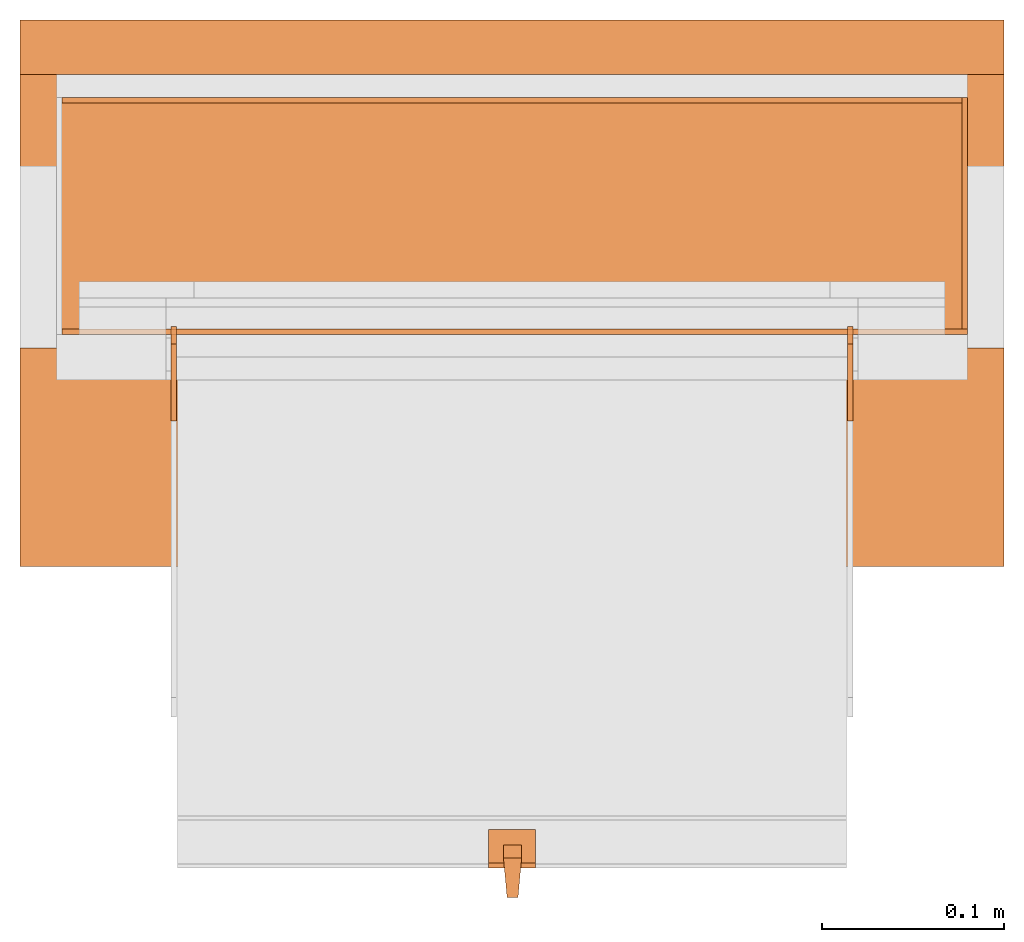
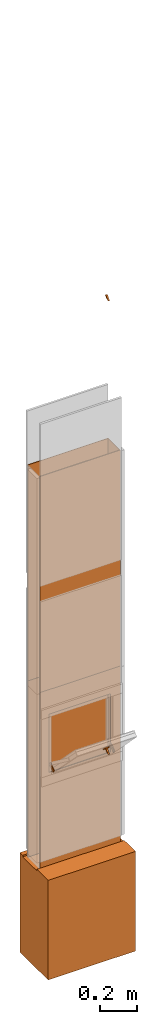
# One storey, part 4 of 4: 12 proxies, 1 opening.
"""IFC2X3 building model written with IfcOpenShell, lengths in metres."""

from ifc_helpers import new_model, entity, si_unit, converted_unit, derived_unit, money_unit, direction, frame, origin_with_axes, origin_2d_with_axis, place, context, subcontext, project, spatial, polyline, rectangle, outline, extrude, boolean, faceted_brep, source, transform, mapped, material, type_object, element, save


model = new_model("IFC2X3")

# Units and contexts
model_context = context("Model", 3, precision=1e-05, world=origin_with_axes(), true_north=direction((0.0, 1.0)))
plan_context = context("Plan", 3, precision=1e-05, world=origin_with_axes(), true_north=direction((0.0, 1.0)))
body_context = subcontext(model_context, "Body", "Model", "MODEL_VIEW")
ifc_project = project(units=[si_unit("LENGTHUNIT", "METRE"), si_unit("AREAUNIT", "SQUARE_METRE"), si_unit("VOLUMEUNIT", "CUBIC_METRE"), converted_unit("PLANEANGLEUNIT", "DEGREE", entity("IfcPlaneAngleMeasure", 0.0174532925199), si_unit("PLANEANGLEUNIT", "RADIAN"), dimensions=[0, 0, 0, 0, 0, 0, 0]), si_unit("SOLIDANGLEUNIT", "STERADIAN"), money_unit("CHF"), converted_unit("TIMEUNIT", "Year", entity("IfcTimeMeasure", 31556926.0), si_unit("TIMEUNIT", "SECOND"), dimensions=[0, 0, 1, 0, 0, 0, 0]), si_unit("MASSUNIT", "GRAM", prefix="KILO"), si_unit("THERMODYNAMICTEMPERATUREUNIT", "DEGREE_CELSIUS"), si_unit("LUMINOUSINTENSITYUNIT", "LUMEN"), si_unit("ENERGYUNIT", "JOULE", prefix="MEGA"), derived_unit("THERMALCONDUCTANCEUNIT", [(si_unit("POWERUNIT", "WATT"), 1), (si_unit("LENGTHUNIT", "METRE"), -1), (si_unit("THERMODYNAMICTEMPERATUREUNIT", "KELVIN"), -1)]), derived_unit("SPECIFICHEATCAPACITYUNIT", [(si_unit("ENERGYUNIT", "JOULE"), 1), (si_unit("MASSUNIT", "GRAM", prefix="KILO"), -1), (si_unit("THERMODYNAMICTEMPERATUREUNIT", "KELVIN"), -1)]), derived_unit("MASSDENSITYUNIT", [(si_unit("MASSUNIT", "GRAM", prefix="KILO"), 1), (si_unit("VOLUMEUNIT", "CUBIC_METRE"), -1)])], contexts=[model_context, plan_context])

# Site, building, storey
site_placement = place(None, origin_with_axes())
site = spatial("IfcSite", under=ifc_project, at=site_placement, CompositionType="ELEMENT")
building_placement = place(site_placement, origin_with_axes())
building = spatial("IfcBuilding", under=site, at=building_placement, CompositionType="ELEMENT")
storey_placement = place(building_placement, origin_with_axes())
storey = spatial("IfcBuildingStorey", under=building, at=storey_placement, Name="EG00", CompositionType="ELEMENT", Elevation=0.0)

# Proxies
ifc_material_1 = material(Name="Metall, Stahl")
building_element_proxy_type_1 = type_object("IfcBuildingElementProxyType", Name="Metall, Stahl 3", PredefinedType="NOTDEFINED")
proxy_1_placement = place(storey_placement, frame((9.61522436818, -8.09743070606, 0.0), z_axis=(0.0, 0.0, 1.0), x_axis=(-1.0, 0.0, 0.0)))
element("IfcBuildingElementProxy", 1, at=proxy_1_placement, inside=storey, type_object=building_element_proxy_type_1, material=ifc_material_1, Name="Wand-008", context=body_context, shape_type="CSG", body=[
    boolean("DIFFERENCE", boolean("DIFFERENCE", extrude(outline(polyline([(0.0, 0.0), (0.5, 0.0), (0.5, 0.003), (0.0, 0.003), (0.0, 0.0)])), origin_with_axes(), (0.0, 0.0, 1.0), 1.15), faceted_brep([(0.497, 0.003, 1.15), (0.497, 0.0, 1.15), (0.5, 0.0, 1.15), (0.5, 0.003, 1.15), (0.497, 0.0, 0.0), (0.497, 0.003, 0.0), (0.5, 0.0, 0.0), (0.5, 0.003, 0.0)], [[[0, 1, 2, 3]], [[4, 1, 0, 5]], [[1, 4, 6, 2]], [[2, 6, 7, 3]], [[5, 0, 3, 7]], [[4, 5, 7, 6]]])), faceted_brep([(0.003, 0.0, 0.0), (0.003, 0.0, 1.15), (0.0, 0.0, 1.15), (0.0, 0.0, 0.0), (0.003, 0.003, 1.15), (0.003, 0.003, 0.0), (0.0, 0.003, 1.15), (0.0, 0.003, 0.0)], [[[0, 1, 2, 3]], [[4, 1, 0, 5]], [[1, 4, 6, 2]], [[6, 7, 3, 2]], [[5, 0, 3, 7]], [[4, 5, 7, 6]]])),
])
proxy_2_placement = place(storey_placement, frame((9.61522436818, -8.22743070606, 0.0), z_axis=(0.0, 0.0, 1.0), x_axis=(0.0, 1.0, 0.0)))
element("IfcBuildingElementProxy", 2, at=proxy_2_placement, inside=storey, type_object=building_element_proxy_type_1, material=ifc_material_1, Name="Wand-007", context=body_context, shape_type="CSG", body=[
    boolean("DIFFERENCE", extrude(outline(polyline([(0.0, 0.0), (0.13, 0.0), (0.13, 0.003), (0.0, 0.003), (0.0, 0.0)])), origin_with_axes(), (0.0, 0.0, 1.0), 1.15), faceted_brep([(0.003, 0.0, 0.0), (0.003, 0.0, 1.15), (0.0, 0.0, 1.15), (0.0, 0.0, 0.0), (0.003, 0.003, 1.15), (0.003, 0.003, 0.0), (0.0, 0.003, 1.15), (0.0, 0.003, 0.0)], [[[0, 1, 2, 3]], [[4, 1, 0, 5]], [[1, 4, 6, 2]], [[6, 7, 3, 2]], [[5, 0, 3, 7]], [[4, 5, 7, 6]]])),
])

# Proxy, opening
proxy_3_placement = place(storey_placement, frame((9.11522436818, -8.22743070606, 0.0), z_axis=(0.0, 0.0, 1.0), x_axis=(1.0, 0.0, 0.0)))
proxy_3 = element("IfcBuildingElementProxy", 3, at=proxy_3_placement, inside=storey, type_object=building_element_proxy_type_1, material=ifc_material_1, Name="Wand-006", context=body_context, shape_type="CSG", body=[
    boolean("DIFFERENCE", extrude(outline(polyline([(0.0, 0.0), (0.5, 0.0), (0.5, 0.003), (0.0, 0.003), (0.0, 0.0)])), origin_with_axes(), (0.0, 0.0, 1.0), 1.15), faceted_brep([(0.003, 0.0, 1.15), (0.003, 0.003, 1.15), (0.0, 0.003, 1.15), (0.0, 0.0, 1.15), (0.003, 0.003, 0.0), (0.003, 0.0, 0.0), (0.0, 0.003, 0.0), (0.0, 0.0, 0.0)], [[[0, 1, 2, 3]], [[4, 1, 0, 5]], [[1, 4, 6, 2]], [[2, 6, 7, 3]], [[5, 0, 3, 7]], [[4, 5, 7, 6]]])),
])
opening_placement = place(proxy_3_placement, frame((-9.11522436818, 8.22743070606, 0.0), z_axis=(0.0, 0.0, 1.0), x_axis=(1.0, 0.0, 0.0)))
element("IfcOpeningElement", 4, at=opening_placement, cuts=proxy_3, Name="031", context=body_context, shape_type="SweptSolid", body=[
    extrude(rectangle(XDim=0.38, YDim=0.38, at=origin_2d_with_axis()), frame((9.36522436818, -8.25243070606, 0.8), z_axis=(0.0, -1.0, 0.0), x_axis=(1.0, 0.0, 0.0)), (0.0, 0.0, -1.0), 0.031),
])

# Proxies
proxy_4_placement = place(storey_placement, frame((9.61522436818, -8.09743070606, 1.15), z_axis=(0.0, 0.0, 1.0), x_axis=(-1.0, 0.0, 0.0)))
element("IfcBuildingElementProxy", 5, at=proxy_4_placement, inside=storey, type_object=building_element_proxy_type_1, material=ifc_material_1, Name="Wand-008", context=body_context, shape_type="CSG", body=[
    boolean("DIFFERENCE", boolean("DIFFERENCE", extrude(outline(polyline([(0.0, 0.0), (0.5, 0.0), (0.5, 0.003), (0.0, 0.003), (0.0, 0.0)])), origin_with_axes(), (0.0, 0.0, 1.0), 1.41), faceted_brep([(0.497, 0.003, 1.41), (0.497, 0.0, 1.41), (0.5, 0.0, 1.41), (0.5, 0.003, 1.41), (0.497, 0.0, 0.0), (0.497, 0.003, 0.0), (0.5, 0.0, 0.0), (0.5, 0.003, 0.0)], [[[0, 1, 2, 3]], [[4, 1, 0, 5]], [[1, 4, 6, 2]], [[2, 6, 7, 3]], [[5, 0, 3, 7]], [[4, 5, 7, 6]]])), faceted_brep([(0.003, 0.0, 0.0), (0.003, 0.0, 1.41), (0.0, 0.0, 1.41), (0.0, 0.0, 0.0), (0.003, 0.003, 1.41), (0.003, 0.003, 0.0), (0.0, 0.003, 1.41), (0.0, 0.003, 0.0)], [[[0, 1, 2, 3]], [[4, 1, 0, 5]], [[1, 4, 6, 2]], [[6, 7, 3, 2]], [[5, 0, 3, 7]], [[4, 5, 7, 6]]])),
])
proxy_5_placement = place(storey_placement, frame((9.61522436818, -8.22743070606, 1.15), z_axis=(0.0, 0.0, 1.0), x_axis=(0.0, 1.0, 0.0)))
element("IfcBuildingElementProxy", 6, at=proxy_5_placement, inside=storey, type_object=building_element_proxy_type_1, material=ifc_material_1, Name="Wand-007", context=body_context, shape_type="CSG", body=[
    boolean("DIFFERENCE", extrude(outline(polyline([(0.0, 0.0), (0.13, 0.0), (0.13, 0.003), (0.0, 0.003), (0.0, 0.0)])), origin_with_axes(), (0.0, 0.0, 1.0), 1.41), faceted_brep([(0.003, 0.0, 0.0), (0.003, 0.0, 1.41), (0.0, 0.0, 1.41), (0.0, 0.0, 0.0), (0.003, 0.003, 1.41), (0.003, 0.003, 0.0), (0.0, 0.003, 1.41), (0.0, 0.003, 0.0)], [[[0, 1, 2, 3]], [[4, 1, 0, 5]], [[1, 4, 6, 2]], [[6, 7, 3, 2]], [[5, 0, 3, 7]], [[4, 5, 7, 6]]])),
])
proxy_6_placement = place(storey_placement, frame((9.11522436818, -8.22743070606, 1.15), z_axis=(0.0, 0.0, 1.0), x_axis=(1.0, 0.0, 0.0)))
element("IfcBuildingElementProxy", 7, at=proxy_6_placement, inside=storey, type_object=building_element_proxy_type_1, material=ifc_material_1, Name="Wand-006", context=body_context, shape_type="CSG", body=[
    boolean("DIFFERENCE", extrude(outline(polyline([(0.0, 0.0), (0.5, 0.0), (0.5, 0.003), (0.0, 0.003), (0.0, 0.0)])), origin_with_axes(), (0.0, 0.0, 1.0), 1.41), faceted_brep([(0.003, 0.0, 1.41), (0.003, 0.003, 1.41), (0.0, 0.003, 1.41), (0.0, 0.0, 1.41), (0.003, 0.003, 0.0), (0.003, 0.0, 0.0), (0.0, 0.003, 0.0), (0.0, 0.0, 0.0)], [[[0, 1, 2, 3]], [[4, 1, 0, 5]], [[1, 4, 6, 2]], [[2, 6, 7, 3]], [[5, 0, 3, 7]], [[4, 5, 7, 6]]])),
])
ifc_material_2 = material(Name="Metall, Aluminium")
building_element_proxy_type_2 = type_object("IfcBuildingElementProxyType", Name="Metall, Aluminium", PredefinedType="NOTDEFINED")
shared_shape_1 = source(origin_with_axes(), body_context, "Body", "Brep", [
    faceted_brep([(16.3891379247, -3.43334637562, 1.097), (16.3891379247, -3.44334637562, 1.097), (16.3921379247, -3.43534637562, 1.13058255688), (16.3991379247, -3.43334637562, 1.097), (16.3991379247, -3.44334637562, 1.097), (16.3921379247, -3.44134637562, 1.13058255688), (16.3961379247, -3.43523159518, 1.13058255688), (16.3961379247, -3.4414517679, 1.13058255688)], [[[0, 1, 2]], [[1, 0, 3, 4]], [[1, 5, 2]], [[0, 2, 3]], [[4, 3, 6]], [[5, 1, 4]], [[2, 5, 7]], [[3, 2, 6]], [[6, 7, 4]], [[7, 5, 4]], [[2, 7, 6]]]),
])
for number, where, z_axis, x_axis, name in (
    (8, (12.8038684551, -19.2080620883, 13.3444423362), (0.0, -0.713898265506, -0.700249431636), (0.0, 0.700249431636, -0.713898265506), "Wand-008"),
    (9, (12.8038684551, -19.2080620883, 16.3044423362), (0.0, -0.713898265506, -0.700249431636), (0.0, 0.700249431636, -0.713898265506), "Wand-008"),
):
    element("IfcBuildingElementProxy", number, at=place(storey_placement, frame(where, z_axis=z_axis, x_axis=x_axis)), inside=storey, type_object=building_element_proxy_type_2, material=ifc_material_2, Name=name, context=body_context, shape_type="MappedRepresentation", body=[
        mapped(shared_shape_1, transform((0.0, 0.0, 0.0))),
    ])
shared_shape_2 = source(origin_with_axes(), body_context, "Body", "Brep", [
    faceted_brep([(16.1345115895, -3.59726483298, 0.726478855326), (16.1345115895, -3.60026483298, 0.726478855326), (16.1345115895, -3.60026483298, 0.776478855326), (16.1345115895, -3.59726483298, 0.776478855326), (16.1525115895, -3.60026483298, 0.726478855326), (16.1525115895, -3.59726483298, 0.726478855326), (16.1525115895, -3.60026483298, 0.776478855326), (16.1525115895, -3.59726483298, 0.776478855326)], [[[0, 1, 2, 3]], [[4, 1, 0, 5]], [[1, 4, 6, 2]], [[2, 6, 7, 3]], [[0, 3, 7, 5]], [[4, 5, 7, 6]]]),
])
for number, where, z_axis, x_axis, name in (
    (10, (13.1494892012, -16.2173099117, 14.7145311427), (0.0, -0.846133712697, -0.532970674838), (0.0, 0.532970674838, -0.846133712697), "Wand-005"),
    (11, (12.7784892012, -16.2173099117, 14.7145311427), (0.0, -0.846133712697, -0.532970674838), (0.0, 0.532970674838, -0.846133712697), "Wand-005"),
):
    element("IfcBuildingElementProxy", number, at=place(storey_placement, frame(where, z_axis=z_axis, x_axis=x_axis)), inside=storey, type_object=building_element_proxy_type_2, material=ifc_material_2, Name=name, context=body_context, shape_type="MappedRepresentation", body=[
        mapped(shared_shape_2, transform((0.0, 0.0, 0.0))),
    ])
shared_shape_3 = source(origin_with_axes(), body_context, "Body", "Brep", [
    faceted_brep([(16.3888858635, -3.43025891523, 1.114), (16.3888858635, -3.43025891523, 1.14), (16.3888858635, -3.40425891523, 1.14), (16.3888858635, -3.40425891523, 1.114), (16.3928858635, -3.43025891523, 1.114), (16.3928858635, -3.43025891523, 1.14), (16.3928858635, -3.40825891523, 1.14), (16.3928858635, -3.40425891523, 1.14), (16.3928858635, -3.40425891523, 1.114), (16.3928858635, -3.40825891523, 1.114)], [[[0, 1, 2, 3]], [[1, 0, 4]], [[2, 1, 5, 6, 7]], [[3, 2, 7, 8]], [[0, 3, 8, 9, 4]], [[1, 4, 5]], [[6, 5, 4]], [[6, 9, 8, 7]], [[9, 6, 4]]]),
])
proxy_7_placement = place(storey_placement, frame((12.7824832834, 3.98081117247, 11.5470677443), z_axis=(0.0, -0.700249431637, 0.713898265506), x_axis=(0.0, -0.713898265506, -0.700249431637)))
element("IfcBuildingElementProxy", 12, at=proxy_7_placement, inside=storey, type_object=building_element_proxy_type_2, material=ifc_material_2, Name="Wand-007", context=body_context, shape_type="MappedRepresentation", body=[
    mapped(shared_shape_3, transform((0.0, 0.0, 0.0))),
])
ifc_material_3 = material(Name="Luft, horizontal")
building_element_proxy_type_3 = type_object("IfcBuildingElementProxyType", Name="Luft, horizontal 650", PredefinedType="NOTDEFINED")
proxy_8_placement = place(storey_placement, frame((9.09522436818, -8.35493070606, 0.01), z_axis=(0.0, 0.0, 1.0), x_axis=(1.0, 0.0, 0.0)))
element("IfcBuildingElementProxy", 13, at=proxy_8_placement, inside=storey, type_object=building_element_proxy_type_3, material=ifc_material_3, Name="Decke-007", context=body_context, shape_type="CSG", body=[
    boolean("DIFFERENCE", extrude(outline(polyline([(0.0, 0.0), (0.54, 0.0), (0.54, 0.3), (0.0, 0.3), (0.0, 0.0)])), frame((0.0, 0.0, -0.649830794263), z_axis=(0.0, 0.0, 1.0), x_axis=(1.0, 0.0, 0.0)), (0.0, 0.0, 1.0), 0.649830794263), faceted_brep([(0.54, 0.12, -0.01), (0.54, 0.27, -0.01), (0.54, 0.27, 0.0), (0.54, 0.12, 0.0), (0.0, 0.12, -0.01), (0.0, 0.27, -0.01), (0.0, 0.27, 0.0), (0.0, 0.12, 0.0)], [[[0, 1, 2, 3]], [[1, 0, 4, 5]], [[6, 2, 1, 5]], [[7, 3, 2, 6]], [[0, 3, 7, 4]], [[4, 7, 6, 5]]])),
])

save(model, "model.ifc")
